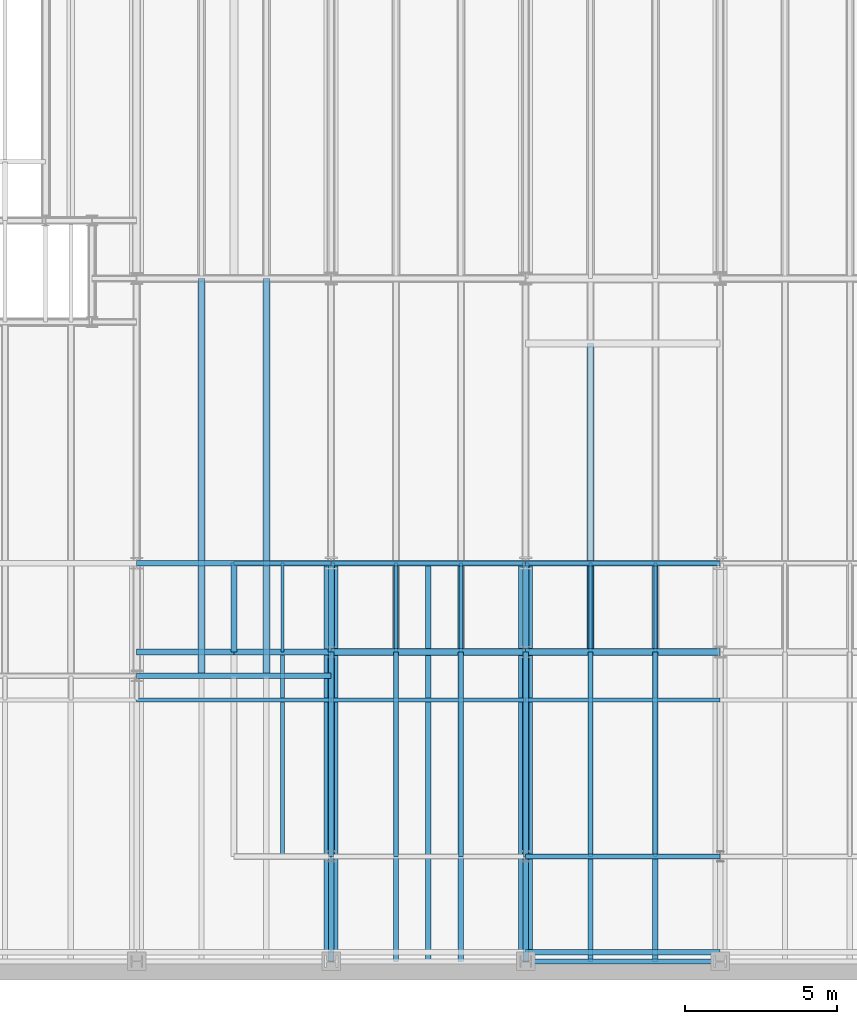
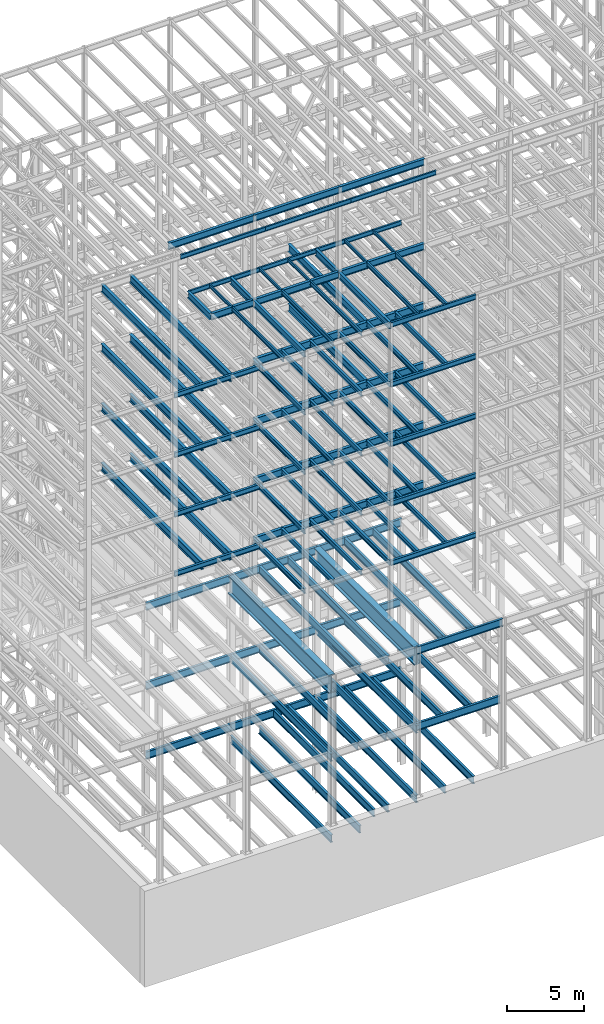
# One storey, part 123 of 150: 108 beams.
"""IFC2X3 building model written with IfcOpenShell, lengths in millimetres."""

from ifc_helpers import new_model, si_unit, frame, origin_with_axes, origin_2d_with_axis, place, context, subcontext, project, spatial, i_section, extrude, material, type_object, element, save


model = new_model("IFC2X3")

# Units and contexts
model_context = context("Model", 3, precision=1e-05, world=origin_with_axes())
body_context = subcontext(model_context, "Body", "Model", "MODEL_VIEW")
ifc_project = project(units=[si_unit("LENGTHUNIT", "METRE", prefix="MILLI"), si_unit("AREAUNIT", "SQUARE_METRE"), si_unit("VOLUMEUNIT", "CUBIC_METRE"), si_unit("MASSUNIT", "GRAM", prefix="KILO"), si_unit("TIMEUNIT", "SECOND"), si_unit("PLANEANGLEUNIT", "RADIAN"), si_unit("SOLIDANGLEUNIT", "STERADIAN"), si_unit("THERMODYNAMICTEMPERATUREUNIT", "DEGREE_CELSIUS"), si_unit("LUMINOUSINTENSITYUNIT", "LUMEN")], contexts=[model_context])

# Site, building, storey
site_placement = place(None, origin_with_axes())
site = spatial("IfcSite", under=ifc_project, at=site_placement, CompositionType="ELEMENT")
building_placement = place(site_placement, origin_with_axes())
building = spatial("IfcBuilding", under=site, at=building_placement, Name="Undefined", CompositionType="ELEMENT")
storey_placement = place(building_placement, origin_with_axes())
storey = spatial("IfcBuildingStorey", under=building, at=storey_placement, Name="Undefined", CompositionType="ELEMENT", Elevation=0.0)

# Beams
ifc_material = material(Name="STEEL/A992")
beam_type_1 = type_object("IfcBeamType", Name="W16X31", PredefinedType="NOTDEFINED")
beam_1_placement = place(storey_placement, frame((24587.2, 3454.4, 59005.7875), z_axis=(0.0, 0.0, 1.0), x_axis=(1.0, 0.0, 0.0)))
element("IfcBeam", 1, at=beam_1_placement, inside=storey, type_object=beam_type_1, material=ifc_material, Name="BEAM", ObjectType="W16X31", context=body_context, shape_type="SweptSolid", body=[
    extrude(i_section(OverallWidth=140.462, OverallDepth=403.225, WebThickness=6.3499, FlangeThickness=11.176, FilletRadius=17.399, at=origin_2d_with_axis()), frame((6400.80000000001, 0.0, 0.0), z_axis=(-1.0, 0.0, 0.0), x_axis=(0.0, -1.0, 0.0)), (0.0, 0.0, 1.0), 6400.8),
])
beam_type_2 = type_object("IfcBeamType", Name="W24X68", PredefinedType="NOTDEFINED")
beam_2_placement = place(storey_placement, frame((26720.8, 10185.4, 54181.375), z_axis=(0.0, 0.0, 1.0), x_axis=(0.0, 1.0, 0.0)))
element("IfcBeam", 2, at=beam_2_placement, inside=storey, type_object=beam_type_2, material=ifc_material, Name="BEAM", ObjectType="W24X68", context=body_context, shape_type="SweptSolid", body=[
    extrude(i_section(OverallWidth=227.838, OverallDepth=603.25, WebThickness=11.1125, FlangeThickness=14.859, FilletRadius=23.2409, at=origin_2d_with_axis()), frame((10160.0, 0.0, 0.0), z_axis=(-1.0, 0.0, 0.0), x_axis=(0.0, -1.0, 0.0)), (0.0, 0.0, 1.0), 10160.0),
])
for number, where, z_axis, x_axis, name in (
    (3, (24587.2, 10185.4, 54181.375), (0.0, 0.0, 1.0), (1.0, 0.0, 0.0), "BEAM"),
    (4, (18186.4, 10185.4, 54181.375), (0.0, 0.0, 1.0), (1.0, 0.0, 0.0), "BEAM"),
):
    element("IfcBeam", number, at=place(storey_placement, frame(where, z_axis=z_axis, x_axis=x_axis)), inside=storey, type_object=beam_type_2, material=ifc_material, Name=name, ObjectType="W24X68", context=body_context, shape_type="SweptSolid", body=[
        extrude(i_section(OverallWidth=227.838, OverallDepth=603.25, WebThickness=11.1125, FlangeThickness=14.859, FilletRadius=23.2409, at=origin_2d_with_axis()), frame((6400.80000000001, 0.0, 0.0), z_axis=(-1.0, 0.0, 0.0), x_axis=(0.0, -1.0, 0.0)), (0.0, 0.0, 1.0), 6400.8),
    ])
for number, where, z_axis, x_axis, name in (
    (5, (16052.8, 9398.0, 54181.375), (0.0, 0.0, 1.0), (0.0, 1.0, 0.0), "BEAM"),
    (6, (13919.2, 9398.0, 54181.375), (0.0, 0.0, 1.0), (0.0, 1.0, 0.0), "BEAM"),
):
    element("IfcBeam", number, at=place(storey_placement, frame(where, z_axis=z_axis, x_axis=x_axis)), inside=storey, type_object=beam_type_2, material=ifc_material, Name=name, ObjectType="W24X68", context=body_context, shape_type="SweptSolid", body=[
        extrude(i_section(OverallWidth=227.838, OverallDepth=603.25, WebThickness=11.1125, FlangeThickness=14.859, FilletRadius=23.2409, at=origin_2d_with_axis()), frame((13081.0, 0.0, 0.0), z_axis=(-1.0, 0.0, 0.0), x_axis=(0.0, -1.0, 0.0)), (0.0, 0.0, 1.0), 13081.0),
    ])
beam_3_placement = place(storey_placement, frame((26720.8, 10185.4, 49456.975), z_axis=(0.0, 0.0, 1.0), x_axis=(0.0, 1.0, 0.0)))
element("IfcBeam", 7, at=beam_3_placement, inside=storey, type_object=beam_type_2, material=ifc_material, Name="BEAM", ObjectType="W24X68", context=body_context, shape_type="SweptSolid", body=[
    extrude(i_section(OverallWidth=227.838, OverallDepth=603.25, WebThickness=11.1125, FlangeThickness=14.859, FilletRadius=23.2409, at=origin_2d_with_axis()), frame((10160.0, 0.0, 0.0), z_axis=(-1.0, 0.0, 0.0), x_axis=(0.0, -1.0, 0.0)), (0.0, 0.0, 1.0), 10160.0),
])
for number, where, z_axis, x_axis, name in (
    (8, (24587.2, 10185.4, 49456.975), (0.0, 0.0, 1.0), (1.0, 0.0, 0.0), "BEAM"),
    (9, (18186.4, 10185.4, 49456.975), (0.0, 0.0, 1.0), (1.0, 0.0, 0.0), "BEAM"),
):
    element("IfcBeam", number, at=place(storey_placement, frame(where, z_axis=z_axis, x_axis=x_axis)), inside=storey, type_object=beam_type_2, material=ifc_material, Name=name, ObjectType="W24X68", context=body_context, shape_type="SweptSolid", body=[
        extrude(i_section(OverallWidth=227.838, OverallDepth=603.25, WebThickness=11.1125, FlangeThickness=14.859, FilletRadius=23.2409, at=origin_2d_with_axis()), frame((6400.80000000001, 0.0, 0.0), z_axis=(-1.0, 0.0, 0.0), x_axis=(0.0, -1.0, 0.0)), (0.0, 0.0, 1.0), 6400.8),
    ])
for number, where, z_axis, x_axis, name in (
    (10, (16052.8, 9398.0, 49456.975), (0.0, 0.0, 1.0), (0.0, 1.0, 0.0), "BEAM"),
    (11, (13919.2, 9398.0, 49456.975), (0.0, 0.0, 1.0), (0.0, 1.0, 0.0), "BEAM"),
):
    element("IfcBeam", number, at=place(storey_placement, frame(where, z_axis=z_axis, x_axis=x_axis)), inside=storey, type_object=beam_type_2, material=ifc_material, Name=name, ObjectType="W24X68", context=body_context, shape_type="SweptSolid", body=[
        extrude(i_section(OverallWidth=227.838, OverallDepth=603.25, WebThickness=11.1125, FlangeThickness=14.859, FilletRadius=23.2409, at=origin_2d_with_axis()), frame((13081.0, 0.0, 0.0), z_axis=(-1.0, 0.0, 0.0), x_axis=(0.0, -1.0, 0.0)), (0.0, 0.0, 1.0), 13081.0),
    ])
for number, where, z_axis, x_axis, name in (
    (12, (24587.2, 10185.4, 44732.575), (0.0, 0.0, 1.0), (1.0, 0.0, 0.0), "BEAM"),
    (13, (18186.4, 10185.4, 44732.575), (0.0, 0.0, 1.0), (1.0, 0.0, 0.0), "BEAM"),
):
    element("IfcBeam", number, at=place(storey_placement, frame(where, z_axis=z_axis, x_axis=x_axis)), inside=storey, type_object=beam_type_2, material=ifc_material, Name=name, ObjectType="W24X68", context=body_context, shape_type="SweptSolid", body=[
        extrude(i_section(OverallWidth=227.838, OverallDepth=603.25, WebThickness=11.1125, FlangeThickness=14.859, FilletRadius=23.2409, at=origin_2d_with_axis()), frame((6400.80000000001, 0.0, 0.0), z_axis=(-1.0, 0.0, 0.0), x_axis=(0.0, -1.0, 0.0)), (0.0, 0.0, 1.0), 6400.8),
    ])
for number, where, z_axis, x_axis, name in (
    (14, (16052.8, 9398.0, 44732.575), (0.0, 0.0, 1.0), (0.0, 1.0, 0.0), "BEAM"),
    (15, (13919.2, 9398.0, 44732.575), (0.0, 0.0, 1.0), (0.0, 1.0, 0.0), "BEAM"),
):
    element("IfcBeam", number, at=place(storey_placement, frame(where, z_axis=z_axis, x_axis=x_axis)), inside=storey, type_object=beam_type_2, material=ifc_material, Name=name, ObjectType="W24X68", context=body_context, shape_type="SweptSolid", body=[
        extrude(i_section(OverallWidth=227.838, OverallDepth=603.25, WebThickness=11.1125, FlangeThickness=14.859, FilletRadius=23.2409, at=origin_2d_with_axis()), frame((13081.0, 0.0, 0.0), z_axis=(-1.0, 0.0, 0.0), x_axis=(0.0, -1.0, 0.0)), (0.0, 0.0, 1.0), 13081.0),
    ])
for number, where, z_axis, x_axis, name in (
    (16, (24587.2, 10185.4, 40008.175), (0.0, 0.0, 1.0), (1.0, 0.0, 0.0), "BEAM"),
    (17, (18186.4, 10185.4, 40008.175), (0.0, 0.0, 1.0), (1.0, 0.0, 0.0), "BEAM"),
):
    element("IfcBeam", number, at=place(storey_placement, frame(where, z_axis=z_axis, x_axis=x_axis)), inside=storey, type_object=beam_type_2, material=ifc_material, Name=name, ObjectType="W24X68", context=body_context, shape_type="SweptSolid", body=[
        extrude(i_section(OverallWidth=227.838, OverallDepth=603.25, WebThickness=11.1125, FlangeThickness=14.859, FilletRadius=23.2409, at=origin_2d_with_axis()), frame((6400.80000000001, 0.0, 0.0), z_axis=(-1.0, 0.0, 0.0), x_axis=(0.0, -1.0, 0.0)), (0.0, 0.0, 1.0), 6400.8),
    ])
for number, where, z_axis, x_axis, name in (
    (18, (16052.8, 9398.0, 40008.175), (0.0, 0.0, 1.0), (0.0, 1.0, 0.0), "BEAM"),
    (19, (13919.2, 9398.0, 40008.175), (0.0, 0.0, 1.0), (0.0, 1.0, 0.0), "BEAM"),
):
    element("IfcBeam", number, at=place(storey_placement, frame(where, z_axis=z_axis, x_axis=x_axis)), inside=storey, type_object=beam_type_2, material=ifc_material, Name=name, ObjectType="W24X68", context=body_context, shape_type="SweptSolid", body=[
        extrude(i_section(OverallWidth=227.838, OverallDepth=603.25, WebThickness=11.1125, FlangeThickness=14.859, FilletRadius=23.2409, at=origin_2d_with_axis()), frame((13081.0, 0.0, 0.0), z_axis=(-1.0, 0.0, 0.0), x_axis=(0.0, -1.0, 0.0)), (0.0, 0.0, 1.0), 13081.0),
    ])
beam_type_3 = type_object("IfcBeamType", Name="W14X22", PredefinedType="NOTDEFINED")
for number, where, z_axis, x_axis, name in (
    (20, (24587.2, 8610.6, 65738.375), (0.0, 0.0, 1.0), (1.0, 0.0, 0.0), "BEAM"),
    (21, (18186.4, 8610.6, 65738.375), (0.0, 0.0, 1.0), (1.0, 0.0, 0.0), "BEAM"),
    (22, (11785.6, 8610.6, 65738.375), (0.0, 0.0, 1.0), (1.0, 0.0, 0.0), "BEAM"),
    (23, (24587.2, 13106.4, 59032.775), (0.0, 0.0, 1.0), (1.0, 0.0, 0.0), "BEAM"),
):
    element("IfcBeam", number, at=place(storey_placement, frame(where, z_axis=z_axis, x_axis=x_axis)), inside=storey, type_object=beam_type_3, material=ifc_material, Name=name, ObjectType="W14X22", context=body_context, shape_type="SweptSolid", body=[
        extrude(i_section(OverallWidth=127.0, OverallDepth=349.25, WebThickness=6.3499, FlangeThickness=8.509, FilletRadius=18.4785, at=origin_2d_with_axis()), frame((6400.80000000001, 0.0, 0.0), z_axis=(-1.0, 0.0, 0.0), x_axis=(0.0, -1.0, 0.0)), (0.0, 0.0, 1.0), 6400.8),
    ])
for number, where, z_axis, x_axis, name in (
    (24, (28854.4, 3454.4, 59032.775), (0.0, 0.0, 1.0), (0.0, 1.0, 0.0), "BEAM"),
    (25, (26720.8, 3454.4, 59032.775), (0.0, 0.0, 1.0), (0.0, 1.0, 0.0), "BEAM"),
):
    element("IfcBeam", number, at=place(storey_placement, frame(where, z_axis=z_axis, x_axis=x_axis)), inside=storey, type_object=beam_type_3, material=ifc_material, Name=name, ObjectType="W14X22", context=body_context, shape_type="SweptSolid", body=[
        extrude(i_section(OverallWidth=127.0, OverallDepth=349.25, WebThickness=6.3499, FlangeThickness=8.509, FilletRadius=18.4785, at=origin_2d_with_axis()), frame((6731.0, 0.0, 0.0), z_axis=(-1.0, 0.0, 0.0), x_axis=(0.0, -1.0, 0.0)), (0.0, 0.0, 1.0), 6731.0),
    ])
beam_4_placement = place(storey_placement, frame((18186.4, 13106.4, 59032.775), z_axis=(0.0, 0.0, 1.0), x_axis=(1.0, 0.0, 0.0)))
element("IfcBeam", 26, at=beam_4_placement, inside=storey, type_object=beam_type_3, material=ifc_material, Name="BEAM", ObjectType="W14X22", context=body_context, shape_type="SweptSolid", body=[
    extrude(i_section(OverallWidth=127.0, OverallDepth=349.25, WebThickness=6.3499, FlangeThickness=8.509, FilletRadius=18.4785, at=origin_2d_with_axis()), frame((6400.80000000001, 0.0, 0.0), z_axis=(-1.0, 0.0, 0.0), x_axis=(0.0, -1.0, 0.0)), (0.0, 0.0, 1.0), 6400.8),
])
for number, where, z_axis, x_axis, name in (
    (27, (22453.6, 3454.4, 59032.775), (0.0, 0.0, 1.0), (0.0, 1.0, 0.0), "BEAM"),
    (28, (20320.0, 3454.4, 59032.775), (0.0, 0.0, 1.0), (0.0, 1.0, 0.0), "BEAM"),
):
    element("IfcBeam", number, at=place(storey_placement, frame(where, z_axis=z_axis, x_axis=x_axis)), inside=storey, type_object=beam_type_3, material=ifc_material, Name=name, ObjectType="W14X22", context=body_context, shape_type="SweptSolid", body=[
        extrude(i_section(OverallWidth=127.0, OverallDepth=349.25, WebThickness=6.3499, FlangeThickness=8.509, FilletRadius=18.4785, at=origin_2d_with_axis()), frame((6731.0, 0.0, 0.0), z_axis=(-1.0, 0.0, 0.0), x_axis=(0.0, -1.0, 0.0)), (0.0, 0.0, 1.0), 6731.0),
    ])
beam_5_placement = place(storey_placement, frame((14986.0, 13106.4, 59032.775), z_axis=(0.0, 0.0, 1.0), x_axis=(1.0, 0.0, 0.0)))
element("IfcBeam", 29, at=beam_5_placement, inside=storey, type_object=beam_type_3, material=ifc_material, Name="BEAM", ObjectType="W14X22", context=body_context, shape_type="SweptSolid", body=[
    extrude(i_section(OverallWidth=127.0, OverallDepth=349.25, WebThickness=6.3499, FlangeThickness=8.509, FilletRadius=18.4785, at=origin_2d_with_axis()), frame((3200.4, 0.0, 0.0), z_axis=(-1.0, 0.0, 0.0), x_axis=(0.0, -1.0, 0.0)), (0.0, 0.0, 1.0), 3200.4),
])
beam_6_placement = place(storey_placement, frame((16586.2, 3454.4, 59032.775), z_axis=(0.0, 0.0, 1.0), x_axis=(0.0, 1.0, 0.0)))
element("IfcBeam", 30, at=beam_6_placement, inside=storey, type_object=beam_type_3, material=ifc_material, Name="BEAM", ObjectType="W14X22", context=body_context, shape_type="SweptSolid", body=[
    extrude(i_section(OverallWidth=127.0, OverallDepth=349.25, WebThickness=6.3499, FlangeThickness=8.509, FilletRadius=18.4785, at=origin_2d_with_axis()), frame((6731.0, 0.0, 0.0), z_axis=(-1.0, 0.0, 0.0), x_axis=(0.0, -1.0, 0.0)), (0.0, 0.0, 1.0), 6731.0),
])
beam_type_4 = type_object("IfcBeamType", Name="W21X55", PredefinedType="NOTDEFINED")
for number, where, z_axis, x_axis, name in (
    (31, (24587.2, 10185.4, 65649.475), (0.0, 0.0, 1.0), (1.0, 0.0, 0.0), "BEAM"),
    (32, (18186.4, 10185.4, 65649.475), (0.0, 0.0, 1.0), (1.0, 0.0, 0.0), "BEAM"),
    (33, (11785.6, 10185.4, 65649.475), (0.0, 0.0, 1.0), (1.0, 0.0, 0.0), "BEAM"),
    (34, (24587.2, 10185.4, 58943.875), (0.0, 0.0, 1.0), (1.0, 0.0, 0.0), "BEAM"),
):
    element("IfcBeam", number, at=place(storey_placement, frame(where, z_axis=z_axis, x_axis=x_axis)), inside=storey, type_object=beam_type_4, material=ifc_material, Name=name, ObjectType="W21X55", context=body_context, shape_type="SweptSolid", body=[
        extrude(i_section(OverallWidth=208.788, OverallDepth=527.05, WebThickness=9.5, FlangeThickness=13.2588, FilletRadius=16.8624, at=origin_2d_with_axis()), frame((6400.80000000001, 0.0, 0.0), z_axis=(-1.0, 0.0, 0.0), x_axis=(0.0, -1.0, 0.0)), (0.0, 0.0, 1.0), 6400.8),
    ])
beam_7_placement = place(storey_placement, frame((24587.2, 10185.4, 58943.875), z_axis=(0.0, 0.0, 1.0), x_axis=(0.0, 1.0, 0.0)))
element("IfcBeam", 35, at=beam_7_placement, inside=storey, type_object=beam_type_4, material=ifc_material, Name="BEAM", ObjectType="W21X55", context=body_context, shape_type="SweptSolid", body=[
    extrude(i_section(OverallWidth=208.788, OverallDepth=527.05, WebThickness=9.5, FlangeThickness=13.2588, FilletRadius=16.8624, at=origin_2d_with_axis()), frame((2921.0, 0.0, 0.0), z_axis=(-1.0, 0.0, 0.0), x_axis=(0.0, -1.0, 0.0)), (0.0, 0.0, 1.0), 2921.0),
])
beam_8_placement = place(storey_placement, frame((24587.2, 3454.4, 58943.875), z_axis=(0.0, 0.0, 1.0), x_axis=(0.0, 1.0, 0.0)))
element("IfcBeam", 36, at=beam_8_placement, inside=storey, type_object=beam_type_4, material=ifc_material, Name="BEAM", ObjectType="W21X55", context=body_context, shape_type="SweptSolid", body=[
    extrude(i_section(OverallWidth=208.788, OverallDepth=527.05, WebThickness=9.5, FlangeThickness=13.2588, FilletRadius=16.8624, at=origin_2d_with_axis()), frame((6731.0, 0.0, 0.0), z_axis=(-1.0, 0.0, 0.0), x_axis=(0.0, -1.0, 0.0)), (0.0, 0.0, 1.0), 6731.0),
])
beam_9_placement = place(storey_placement, frame((14986.0, 10185.4, 58943.875), z_axis=(0.0, 0.0, 1.0), x_axis=(0.0, 1.0, 0.0)))
element("IfcBeam", 37, at=beam_9_placement, inside=storey, type_object=beam_type_4, material=ifc_material, Name="BEAM", ObjectType="W21X55", context=body_context, shape_type="SweptSolid", body=[
    extrude(i_section(OverallWidth=208.788, OverallDepth=527.05, WebThickness=9.5, FlangeThickness=13.2588, FilletRadius=16.8624, at=origin_2d_with_axis()), frame((2921.0, 0.0, 0.0), z_axis=(-1.0, 0.0, 0.0), x_axis=(0.0, -1.0, 0.0)), (0.0, 0.0, 1.0), 2921.0),
])
beam_10_placement = place(storey_placement, frame((18186.4, 10185.4, 58943.875), z_axis=(0.0, 0.0, 1.0), x_axis=(1.0, 0.0, 0.0)))
element("IfcBeam", 38, at=beam_10_placement, inside=storey, type_object=beam_type_4, material=ifc_material, Name="BEAM", ObjectType="W21X55", context=body_context, shape_type="SweptSolid", body=[
    extrude(i_section(OverallWidth=208.788, OverallDepth=527.05, WebThickness=9.5, FlangeThickness=13.2588, FilletRadius=16.8624, at=origin_2d_with_axis()), frame((6400.80000000001, 0.0, 0.0), z_axis=(-1.0, 0.0, 0.0), x_axis=(0.0, -1.0, 0.0)), (0.0, 0.0, 1.0), 6400.8),
])
beam_11_placement = place(storey_placement, frame((14986.0, 10185.4, 58943.875), z_axis=(0.0, 0.0, 1.0), x_axis=(1.0, 0.0, 0.0)))
element("IfcBeam", 39, at=beam_11_placement, inside=storey, type_object=beam_type_4, material=ifc_material, Name="BEAM", ObjectType="W21X55", context=body_context, shape_type="SweptSolid", body=[
    extrude(i_section(OverallWidth=208.788, OverallDepth=527.05, WebThickness=9.5, FlangeThickness=13.2588, FilletRadius=16.8624, at=origin_2d_with_axis()), frame((3200.4, 0.0, 0.0), z_axis=(-1.0, 0.0, 0.0), x_axis=(0.0, -1.0, 0.0)), (0.0, 0.0, 1.0), 3200.4),
])
beam_12_placement = place(storey_placement, frame((18186.4, 10185.4, 58943.875), z_axis=(0.0, 0.0, 1.0), x_axis=(0.0, 1.0, 0.0)))
element("IfcBeam", 40, at=beam_12_placement, inside=storey, type_object=beam_type_4, material=ifc_material, Name="BEAM", ObjectType="W21X55", context=body_context, shape_type="SweptSolid", body=[
    extrude(i_section(OverallWidth=208.788, OverallDepth=527.05, WebThickness=9.5, FlangeThickness=13.2588, FilletRadius=16.8624, at=origin_2d_with_axis()), frame((2921.0, 0.0, 0.0), z_axis=(-1.0, 0.0, 0.0), x_axis=(0.0, -1.0, 0.0)), (0.0, 0.0, 1.0), 2921.0),
])
beam_13_placement = place(storey_placement, frame((18186.4, 3454.4, 58943.875), z_axis=(0.0, 0.0, 1.0), x_axis=(0.0, 1.0, 0.0)))
element("IfcBeam", 41, at=beam_13_placement, inside=storey, type_object=beam_type_4, material=ifc_material, Name="BEAM", ObjectType="W21X55", context=body_context, shape_type="SweptSolid", body=[
    extrude(i_section(OverallWidth=208.788, OverallDepth=527.05, WebThickness=9.5, FlangeThickness=13.2588, FilletRadius=16.8624, at=origin_2d_with_axis()), frame((6731.0, 0.0, 0.0), z_axis=(-1.0, 0.0, 0.0), x_axis=(0.0, -1.0, 0.0)), (0.0, 0.0, 1.0), 6731.0),
])
beam_type_5 = type_object("IfcBeamType", Name="W10X15", PredefinedType="NOTDEFINED")
for number, where, z_axis, x_axis, name in (
    (42, (28854.4, 10185.4, 59080.4), (0.0, 0.0, 1.0), (0.0, 1.0, 0.0), "BEAM"),
    (43, (26720.8, 10185.4, 59080.4), (0.0, 0.0, 1.0), (0.0, 1.0, 0.0), "BEAM"),
    (44, (22453.6, 10185.4, 59080.4), (0.0, 0.0, 1.0), (0.0, 1.0, 0.0), "BEAM"),
    (45, (20320.0, 10185.4, 59080.4), (0.0, 0.0, 1.0), (0.0, 1.0, 0.0), "BEAM"),
    (46, (16586.2, 10185.4, 59080.4), (0.0, 0.0, 1.0), (0.0, 1.0, 0.0), "BEAM"),
):
    element("IfcBeam", number, at=place(storey_placement, frame(where, z_axis=z_axis, x_axis=x_axis)), inside=storey, type_object=beam_type_5, material=ifc_material, Name=name, ObjectType="W10X15", context=body_context, shape_type="SweptSolid", body=[
        extrude(i_section(OverallWidth=101.6, OverallDepth=254.0, WebThickness=6.3499, FlangeThickness=6.858, FilletRadius=13.7795, at=origin_2d_with_axis()), frame((2921.0, 0.0, 0.0), z_axis=(-1.0, 0.0, 0.0), x_axis=(0.0, -1.0, 0.0)), (0.0, 0.0, 1.0), 2921.0),
    ])
beam_type_6 = type_object("IfcBeamType", Name="W16X36", PredefinedType="NOTDEFINED")
for number, where, z_axis, x_axis, name in (
    (47, (24587.2, 3454.4, 54281.3875), (0.0, 0.0, 1.0), (1.0, 0.0, 0.0), "BEAM"),
    (48, (11785.6, 9398.0, 54281.3875), (0.0, 0.0, 1.0), (1.0, 0.0, 0.0), "BEAM"),
):
    element("IfcBeam", number, at=place(storey_placement, frame(where, z_axis=z_axis, x_axis=x_axis)), inside=storey, type_object=beam_type_6, material=ifc_material, Name=name, ObjectType="W16X36", context=body_context, shape_type="SweptSolid", body=[
        extrude(i_section(OverallWidth=177.8, OverallDepth=403.225, WebThickness=7.9375, FlangeThickness=10.922, FilletRadius=17.6529, at=origin_2d_with_axis()), frame((6400.80000000001, 0.0, 0.0), z_axis=(-1.0, 0.0, 0.0), x_axis=(0.0, -1.0, 0.0)), (0.0, 0.0, 1.0), 6400.8),
    ])
for number, where, z_axis, x_axis, name in (
    (49, (28854.4, 3454.4, 54281.3875), (0.0, 0.0, 1.0), (0.0, 1.0, 0.0), "BEAM"),
    (50, (26720.8, 3454.4, 54281.3875), (0.0, 0.0, 1.0), (0.0, 1.0, 0.0), "BEAM"),
    (51, (24587.2, 3454.4, 54281.3875), (0.0, 0.0, 1.0), (0.0, 1.0, 0.0), "BEAM"),
    (52, (22453.6, 3454.4, 54281.3875), (0.0, 0.0, 1.0), (0.0, 1.0, 0.0), "BEAM"),
    (53, (20320.0, 3454.4, 54281.3875), (0.0, 0.0, 1.0), (0.0, 1.0, 0.0), "BEAM"),
    (54, (18186.4, 3454.4, 54281.3875), (0.0, 0.0, 1.0), (0.0, 1.0, 0.0), "BEAM"),
):
    element("IfcBeam", number, at=place(storey_placement, frame(where, z_axis=z_axis, x_axis=x_axis)), inside=storey, type_object=beam_type_6, material=ifc_material, Name=name, ObjectType="W16X36", context=body_context, shape_type="SweptSolid", body=[
        extrude(i_section(OverallWidth=177.8, OverallDepth=403.225, WebThickness=7.9375, FlangeThickness=10.922, FilletRadius=17.6529, at=origin_2d_with_axis()), frame((6731.0, 0.0, 0.0), z_axis=(-1.0, 0.0, 0.0), x_axis=(0.0, -1.0, 0.0)), (0.0, 0.0, 1.0), 6731.0),
    ])
for number, where, z_axis, x_axis, name in (
    (55, (24587.2, 3454.4, 49556.9875), (0.0, 0.0, 1.0), (1.0, 0.0, 0.0), "BEAM"),
    (56, (11785.6, 9398.0, 49556.9875), (0.0, 0.0, 1.0), (1.0, 0.0, 0.0), "BEAM"),
):
    element("IfcBeam", number, at=place(storey_placement, frame(where, z_axis=z_axis, x_axis=x_axis)), inside=storey, type_object=beam_type_6, material=ifc_material, Name=name, ObjectType="W16X36", context=body_context, shape_type="SweptSolid", body=[
        extrude(i_section(OverallWidth=177.8, OverallDepth=403.225, WebThickness=7.9375, FlangeThickness=10.922, FilletRadius=17.6529, at=origin_2d_with_axis()), frame((6400.80000000001, 0.0, 0.0), z_axis=(-1.0, 0.0, 0.0), x_axis=(0.0, -1.0, 0.0)), (0.0, 0.0, 1.0), 6400.8),
    ])
for number, where, z_axis, x_axis, name in (
    (57, (28854.4, 3454.4, 49556.9875), (0.0, 0.0, 1.0), (0.0, 1.0, 0.0), "BEAM"),
    (58, (26720.8, 3454.4, 49556.9875), (0.0, 0.0, 1.0), (0.0, 1.0, 0.0), "BEAM"),
    (59, (24587.2, 3454.4, 49556.9875), (0.0, 0.0, 1.0), (0.0, 1.0, 0.0), "BEAM"),
    (60, (22453.6, 3454.4, 49556.9875), (0.0, 0.0, 1.0), (0.0, 1.0, 0.0), "BEAM"),
    (61, (20320.0, 3454.4, 49556.9875), (0.0, 0.0, 1.0), (0.0, 1.0, 0.0), "BEAM"),
    (62, (18186.4, 3454.4, 49556.9875), (0.0, 0.0, 1.0), (0.0, 1.0, 0.0), "BEAM"),
):
    element("IfcBeam", number, at=place(storey_placement, frame(where, z_axis=z_axis, x_axis=x_axis)), inside=storey, type_object=beam_type_6, material=ifc_material, Name=name, ObjectType="W16X36", context=body_context, shape_type="SweptSolid", body=[
        extrude(i_section(OverallWidth=177.8, OverallDepth=403.225, WebThickness=7.9375, FlangeThickness=10.922, FilletRadius=17.6529, at=origin_2d_with_axis()), frame((6731.0, 0.0, 0.0), z_axis=(-1.0, 0.0, 0.0), x_axis=(0.0, -1.0, 0.0)), (0.0, 0.0, 1.0), 6731.0),
    ])
for number, where, z_axis, x_axis, name in (
    (63, (24587.2, 3454.4, 44832.5875), (0.0, 0.0, 1.0), (1.0, 0.0, 0.0), "BEAM"),
    (64, (11785.6, 9398.0, 44832.5875), (0.0, 0.0, 1.0), (1.0, 0.0, 0.0), "BEAM"),
):
    element("IfcBeam", number, at=place(storey_placement, frame(where, z_axis=z_axis, x_axis=x_axis)), inside=storey, type_object=beam_type_6, material=ifc_material, Name=name, ObjectType="W16X36", context=body_context, shape_type="SweptSolid", body=[
        extrude(i_section(OverallWidth=177.8, OverallDepth=403.225, WebThickness=7.9375, FlangeThickness=10.922, FilletRadius=17.6529, at=origin_2d_with_axis()), frame((6400.80000000001, 0.0, 0.0), z_axis=(-1.0, 0.0, 0.0), x_axis=(0.0, -1.0, 0.0)), (0.0, 0.0, 1.0), 6400.8),
    ])
for number, where, z_axis, x_axis, name in (
    (65, (28854.4, 3454.4, 44832.5875), (0.0, 0.0, 1.0), (0.0, 1.0, 0.0), "BEAM"),
    (66, (26720.8, 3454.4, 44832.5875), (0.0, 0.0, 1.0), (0.0, 1.0, 0.0), "BEAM"),
    (67, (24587.2, 3454.4, 44832.5875), (0.0, 0.0, 1.0), (0.0, 1.0, 0.0), "BEAM"),
    (68, (22453.6, 3454.4, 44832.5875), (0.0, 0.0, 1.0), (0.0, 1.0, 0.0), "BEAM"),
    (69, (20320.0, 3454.4, 44832.5875), (0.0, 0.0, 1.0), (0.0, 1.0, 0.0), "BEAM"),
    (70, (18186.4, 3454.4, 44832.5875), (0.0, 0.0, 1.0), (0.0, 1.0, 0.0), "BEAM"),
):
    element("IfcBeam", number, at=place(storey_placement, frame(where, z_axis=z_axis, x_axis=x_axis)), inside=storey, type_object=beam_type_6, material=ifc_material, Name=name, ObjectType="W16X36", context=body_context, shape_type="SweptSolid", body=[
        extrude(i_section(OverallWidth=177.8, OverallDepth=403.225, WebThickness=7.9375, FlangeThickness=10.922, FilletRadius=17.6529, at=origin_2d_with_axis()), frame((6731.0, 0.0, 0.0), z_axis=(-1.0, 0.0, 0.0), x_axis=(0.0, -1.0, 0.0)), (0.0, 0.0, 1.0), 6731.0),
    ])
for number, where, z_axis, x_axis, name in (
    (71, (24587.2, 3454.4, 40108.1875), (0.0, 0.0, 1.0), (1.0, 0.0, 0.0), "BEAM"),
    (72, (11785.6, 9398.0, 40108.1875), (0.0, 0.0, 1.0), (1.0, 0.0, 0.0), "BEAM"),
):
    element("IfcBeam", number, at=place(storey_placement, frame(where, z_axis=z_axis, x_axis=x_axis)), inside=storey, type_object=beam_type_6, material=ifc_material, Name=name, ObjectType="W16X36", context=body_context, shape_type="SweptSolid", body=[
        extrude(i_section(OverallWidth=177.8, OverallDepth=403.225, WebThickness=7.9375, FlangeThickness=10.922, FilletRadius=17.6529, at=origin_2d_with_axis()), frame((6400.80000000001, 0.0, 0.0), z_axis=(-1.0, 0.0, 0.0), x_axis=(0.0, -1.0, 0.0)), (0.0, 0.0, 1.0), 6400.8),
    ])
for number, where, z_axis, x_axis, name in (
    (73, (28854.4, 3454.4, 40108.1875), (0.0, 0.0, 1.0), (0.0, 1.0, 0.0), "BEAM"),
    (74, (26720.8, 3454.4, 40108.1875), (0.0, 0.0, 1.0), (0.0, 1.0, 0.0), "BEAM"),
    (75, (24587.2, 3454.4, 40108.1875), (0.0, 0.0, 1.0), (0.0, 1.0, 0.0), "BEAM"),
    (76, (22453.6, 3454.4, 40108.1875), (0.0, 0.0, 1.0), (0.0, 1.0, 0.0), "BEAM"),
    (77, (20320.0, 3454.4, 40108.1875), (0.0, 0.0, 1.0), (0.0, 1.0, 0.0), "BEAM"),
    (78, (18186.4, 3454.4, 40108.1875), (0.0, 0.0, 1.0), (0.0, 1.0, 0.0), "BEAM"),
):
    element("IfcBeam", number, at=place(storey_placement, frame(where, z_axis=z_axis, x_axis=x_axis)), inside=storey, type_object=beam_type_6, material=ifc_material, Name=name, ObjectType="W16X36", context=body_context, shape_type="SweptSolid", body=[
        extrude(i_section(OverallWidth=177.8, OverallDepth=403.225, WebThickness=7.9375, FlangeThickness=10.922, FilletRadius=17.6529, at=origin_2d_with_axis()), frame((6731.0, 0.0, 0.0), z_axis=(-1.0, 0.0, 0.0), x_axis=(0.0, -1.0, 0.0)), (0.0, 0.0, 1.0), 6731.0),
    ])
beam_type_7 = type_object("IfcBeamType", Name="W24X62", PredefinedType="NOTDEFINED")
beam_14_placement = place(storey_placement, frame((24587.2, 0.0, 35283.775), z_axis=(0.0, 0.0, 1.0), x_axis=(1.0, 0.0, 0.0)))
element("IfcBeam", 79, at=beam_14_placement, inside=storey, type_object=beam_type_7, material=ifc_material, Name="BEAM", ObjectType="W24X62", context=body_context, shape_type="SweptSolid", body=[
    extrude(i_section(OverallWidth=177.8, OverallDepth=603.25, WebThickness=11.1125, FlangeThickness=14.986, FilletRadius=23.114, at=origin_2d_with_axis()), frame((6400.80000000001, 0.0, 0.0), z_axis=(-1.0, 0.0, 0.0), x_axis=(0.0, -1.0, 0.0)), (0.0, 0.0, 1.0), 6400.8),
])
for number, where, z_axis, x_axis, name in (
    (80, (28854.4, 0.0, 35283.775), (0.0, 0.0, 1.0), (0.0, 1.0, 0.0), "BEAM"),
    (81, (26720.8, 0.0, 35283.775), (0.0, 0.0, 1.0), (0.0, 1.0, 0.0), "BEAM"),
    (82, (22453.6, 0.0, 35283.775), (0.0, 0.0, 1.0), (0.0, 1.0, 0.0), "BEAM"),
    (83, (20320.0, 0.0, 35283.775), (0.0, 0.0, 1.0), (0.0, 1.0, 0.0), "BEAM"),
):
    element("IfcBeam", number, at=place(storey_placement, frame(where, z_axis=z_axis, x_axis=x_axis)), inside=storey, type_object=beam_type_7, material=ifc_material, Name=name, ObjectType="W24X62", context=body_context, shape_type="SweptSolid", body=[
        extrude(i_section(OverallWidth=177.8, OverallDepth=603.25, WebThickness=11.1125, FlangeThickness=14.986, FilletRadius=23.114, at=origin_2d_with_axis()), frame((13106.4, 0.0, 0.0), z_axis=(-1.0, 0.0, 0.0), x_axis=(0.0, -1.0, 0.0)), (0.0, 0.0, 1.0), 13106.4),
    ])
for number, where, z_axis, x_axis, name in (
    (84, (24587.2, 13106.4, 35283.775), (0.0, 0.0, 1.0), (1.0, 0.0, 0.0), "BEAM"),
    (85, (18186.4, 13106.4, 35283.775), (0.0, 0.0, 1.0), (1.0, 0.0, 0.0), "BEAM"),
    (86, (11785.6, 13106.4, 35283.775), (0.0, 0.0, 1.0), (1.0, 0.0, 0.0), "BEAM"),
    (87, (24587.2, 13106.4, 28984.575), (0.0, 0.0, 1.0), (1.0, 0.0, 0.0), "BEAM"),
    (88, (18186.4, 13106.4, 28984.575), (0.0, 0.0, 1.0), (1.0, 0.0, 0.0), "BEAM"),
    (89, (11785.6, 13106.4, 28984.575), (0.0, 0.0, 1.0), (1.0, 0.0, 0.0), "BEAM"),
):
    element("IfcBeam", number, at=place(storey_placement, frame(where, z_axis=z_axis, x_axis=x_axis)), inside=storey, type_object=beam_type_7, material=ifc_material, Name=name, ObjectType="W24X62", context=body_context, shape_type="SweptSolid", body=[
        extrude(i_section(OverallWidth=177.8, OverallDepth=603.25, WebThickness=11.1125, FlangeThickness=14.986, FilletRadius=23.114, at=origin_2d_with_axis()), frame((6400.80000000001, 0.0, 0.0), z_axis=(-1.0, 0.0, 0.0), x_axis=(0.0, -1.0, 0.0)), (0.0, 0.0, 1.0), 6400.8),
    ])
for number, where, z_axis, x_axis, name in (
    (90, (28854.4, 304.8, 28984.575), (0.0, 0.0, 1.0), (0.0, 1.0, 0.0), "BEAM"),
    (91, (26720.8, 304.8, 28984.575), (0.0, 0.0, 1.0), (0.0, 1.0, 0.0), "BEAM"),
):
    element("IfcBeam", number, at=place(storey_placement, frame(where, z_axis=z_axis, x_axis=x_axis)), inside=storey, type_object=beam_type_7, material=ifc_material, Name=name, ObjectType="W24X62", context=body_context, shape_type="SweptSolid", body=[
        extrude(i_section(OverallWidth=177.8, OverallDepth=603.25, WebThickness=11.1125, FlangeThickness=14.986, FilletRadius=23.114, at=origin_2d_with_axis()), frame((12801.6, 0.0, 0.0), z_axis=(-1.0, 0.0, 0.0), x_axis=(0.0, -1.0, 0.0)), (0.0, 0.0, 1.0), 12801.6),
    ])
beam_15_placement = place(storey_placement, frame((24587.2, 0.0, 28984.575), z_axis=(0.0, 0.0, 1.0), x_axis=(0.0, 1.0, 0.0)))
element("IfcBeam", 92, at=beam_15_placement, inside=storey, type_object=beam_type_7, material=ifc_material, Name="BEAM", ObjectType="W24X62", context=body_context, shape_type="SweptSolid", body=[
    extrude(i_section(OverallWidth=177.8, OverallDepth=603.25, WebThickness=11.1125, FlangeThickness=14.986, FilletRadius=23.114, at=origin_2d_with_axis()), frame((13106.4, 0.0, 0.0), z_axis=(-1.0, 0.0, 0.0), x_axis=(0.0, -1.0, 0.0)), (0.0, 0.0, 1.0), 13106.4),
])
for number, where, z_axis, x_axis, name in (
    (93, (22453.6, 304.8, 28984.575), (0.0, 0.0, 1.0), (0.0, 1.0, 0.0), "BEAM"),
    (94, (20320.0, 304.8, 28984.575), (0.0, 0.0, 1.0), (0.0, 1.0, 0.0), "BEAM"),
):
    element("IfcBeam", number, at=place(storey_placement, frame(where, z_axis=z_axis, x_axis=x_axis)), inside=storey, type_object=beam_type_7, material=ifc_material, Name=name, ObjectType="W24X62", context=body_context, shape_type="SweptSolid", body=[
        extrude(i_section(OverallWidth=177.8, OverallDepth=603.25, WebThickness=11.1125, FlangeThickness=14.986, FilletRadius=23.114, at=origin_2d_with_axis()), frame((12801.6, 0.0, 0.0), z_axis=(-1.0, 0.0, 0.0), x_axis=(0.0, -1.0, 0.0)), (0.0, 0.0, 1.0), 12801.6),
    ])
beam_16_placement = place(storey_placement, frame((18186.4, 0.0, 28984.575), z_axis=(0.0, 0.0, 1.0), x_axis=(0.0, 1.0, 0.0)))
element("IfcBeam", 95, at=beam_16_placement, inside=storey, type_object=beam_type_7, material=ifc_material, Name="BEAM", ObjectType="W24X62", context=body_context, shape_type="SweptSolid", body=[
    extrude(i_section(OverallWidth=177.8, OverallDepth=603.25, WebThickness=11.1125, FlangeThickness=14.986, FilletRadius=23.114, at=origin_2d_with_axis()), frame((13106.4, 0.0, 0.0), z_axis=(-1.0, 0.0, 0.0), x_axis=(0.0, -1.0, 0.0)), (0.0, 0.0, 1.0), 13106.4),
])
for number, where, z_axis, x_axis, name in (
    (96, (24587.2, 304.8, 28984.575), (0.0, 0.0, 1.0), (1.0, 0.0, 0.0), "BEAM"),
    (97, (24587.2, 13106.4, 23472.775), (0.0, 0.0, 1.0), (1.0, 0.0, 0.0), "BEAM"),
    (98, (18186.4, 13106.4, 23472.775), (0.0, 0.0, 1.0), (1.0, 0.0, 0.0), "BEAM"),
    (99, (11785.6, 13106.4, 23472.775), (0.0, 0.0, 1.0), (1.0, 0.0, 0.0), "BEAM"),
):
    element("IfcBeam", number, at=place(storey_placement, frame(where, z_axis=z_axis, x_axis=x_axis)), inside=storey, type_object=beam_type_7, material=ifc_material, Name=name, ObjectType="W24X62", context=body_context, shape_type="SweptSolid", body=[
        extrude(i_section(OverallWidth=177.8, OverallDepth=603.25, WebThickness=11.1125, FlangeThickness=14.986, FilletRadius=23.114, at=origin_2d_with_axis()), frame((6400.80000000001, 0.0, 0.0), z_axis=(-1.0, 0.0, 0.0), x_axis=(0.0, -1.0, 0.0)), (0.0, 0.0, 1.0), 6400.8),
    ])
for number, where, z_axis, x_axis, name in (
    (100, (21386.8, 0.0, 23472.775), (0.0, 0.0, 1.0), (0.0, 1.0, 0.0), "BEAM"),
    (101, (28854.4, 0.0, 23472.775), (0.0, 0.0, 1.0), (0.0, 1.0, 0.0), "BEAM"),
    (102, (26720.8, 0.0, 23472.775), (0.0, 0.0, 1.0), (0.0, 1.0, 0.0), "BEAM"),
    (103, (24587.2, 0.0, 23472.775), (0.0, 0.0, 1.0), (0.0, 1.0, 0.0), "BEAM"),
    (104, (22453.6, 0.0, 23472.775), (0.0, 0.0, 1.0), (0.0, 1.0, 0.0), "BEAM"),
    (105, (20320.0, 0.0, 22558.375), (0.0, 0.0, 1.0), (0.0, 1.0, 0.0), "BEAM"),
    (106, (18186.4, 0.0, 22558.375), (0.0, 0.0, 1.0), (0.0, 1.0, 0.0), "BEAM"),
):
    element("IfcBeam", number, at=place(storey_placement, frame(where, z_axis=z_axis, x_axis=x_axis)), inside=storey, type_object=beam_type_7, material=ifc_material, Name=name, ObjectType="W24X62", context=body_context, shape_type="SweptSolid", body=[
        extrude(i_section(OverallWidth=177.8, OverallDepth=603.25, WebThickness=11.1125, FlangeThickness=14.986, FilletRadius=23.114, at=origin_2d_with_axis()), frame((13106.4, 0.0, 0.0), z_axis=(-1.0, 0.0, 0.0), x_axis=(0.0, -1.0, 0.0)), (0.0, 0.0, 1.0), 13106.4),
    ])
beam_type_8 = type_object("IfcBeamType", PredefinedType="NOTDEFINED")
for number, where, z_axis, x_axis, name in (
    (107, (24587.2, 0.0, 34861.5), (0.0, 0.0, 1.0), (0.0, 1.0, 0.0), "BEAM"),
    (108, (18186.4, 0.0, 34861.5), (0.0, 0.0, 1.0), (0.0, 1.0, 0.0), "BEAM"),
):
    element("IfcBeam", number, at=place(storey_placement, frame(where, z_axis=z_axis, x_axis=x_axis)), inside=storey, type_object=beam_type_8, material=ifc_material, Name=name, context=body_context, shape_type="SweptSolid", body=[
        extrude(i_section(OverallWidth=457.2, OverallDepth=1447.8, WebThickness=44.45, FlangeThickness=88.9, FilletRadius=31.115, at=origin_2d_with_axis()), frame((13106.4, 0.0, 0.0), z_axis=(-1.0, 0.0, 0.0), x_axis=(0.0, -1.0, 0.0)), (0.0, 0.0, 1.0), 13106.4),
    ])

save(model, "model.ifc")
